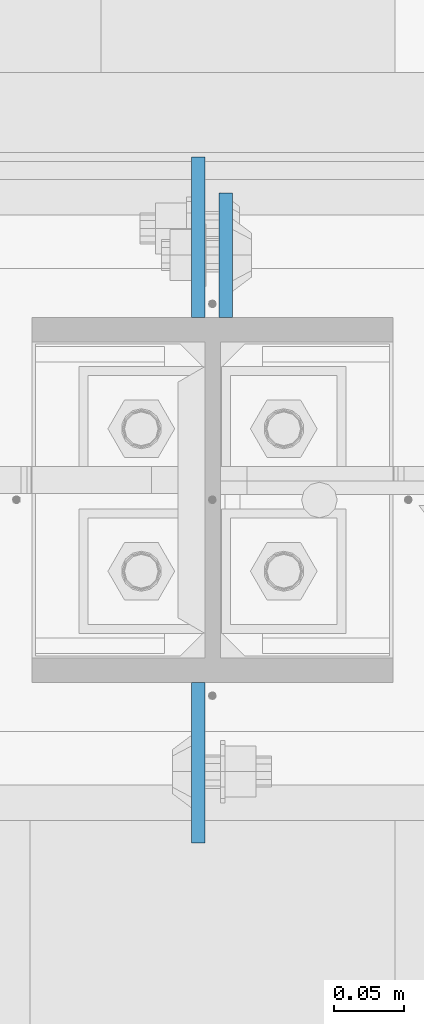
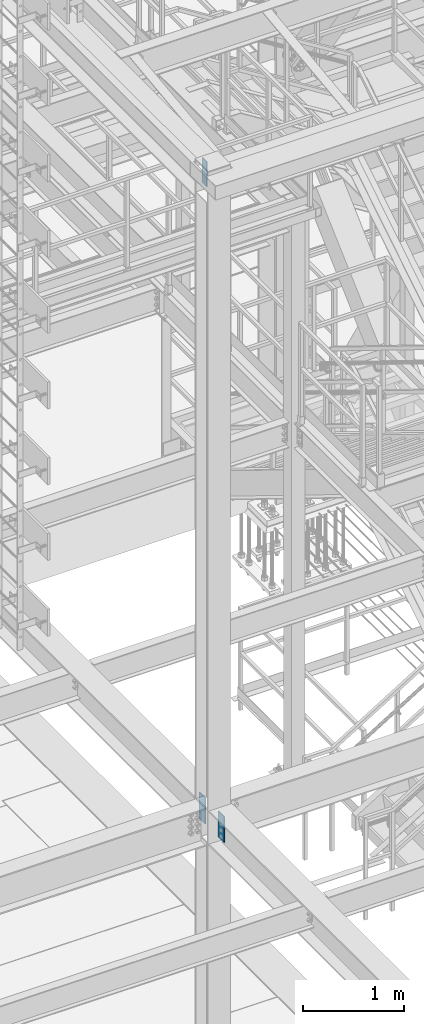
# One storey, part 1466 of 3843: 3 columns, 1 element without a shape of its own.
"""IFC2X3 building model written with IfcOpenShell, lengths in millimetres."""

from ifc_helpers import new_model, si_unit, frame, origin_with_axes, place, context, subcontext, project, spatial, faceted_brep, material, type_object, element, aggregate, save


model = new_model("IFC2X3")

# Units and contexts
model_context = context("Model", 3, precision=1e-05, world=origin_with_axes())
body_context = subcontext(model_context, "Body", "Model", "MODEL_VIEW")
ifc_project = project(units=[si_unit("LENGTHUNIT", "METRE", prefix="MILLI"), si_unit("AREAUNIT", "SQUARE_METRE"), si_unit("VOLUMEUNIT", "CUBIC_METRE"), si_unit("MASSUNIT", "GRAM", prefix="KILO"), si_unit("TIMEUNIT", "SECOND"), si_unit("PLANEANGLEUNIT", "RADIAN"), si_unit("SOLIDANGLEUNIT", "STERADIAN"), si_unit("THERMODYNAMICTEMPERATUREUNIT", "DEGREE_CELSIUS"), si_unit("LUMINOUSINTENSITYUNIT", "LUMEN")], contexts=[model_context])

# Site, building, storey
site_placement = place(None, origin_with_axes())
site = spatial("IfcSite", under=ifc_project, at=site_placement, CompositionType="ELEMENT")
building_placement = place(site_placement, origin_with_axes())
building = spatial("IfcBuilding", under=site, at=building_placement, Name="Undefined", CompositionType="ELEMENT")
storey_placement = place(building_placement, origin_with_axes())
storey = spatial("IfcBuildingStorey", under=building, at=storey_placement, Name="Undefined", CompositionType="ELEMENT", Elevation=0.0)

# Assembly, columns
assembly_placement = place(storey_placement, origin_with_axes())
assembly = element("IfcElementAssembly", 1, at=assembly_placement, inside=storey, Name="COLUMN", AssemblyPlace="NOTDEFINED", PredefinedType="RIGID_FRAME")
ifc_material = material(Name="STEEL/A572-50")
column_type_1 = type_object("IfcColumnType", PredefinedType="NOTDEFINED")
column_1_placement = place(assembly_placement, frame((49006.125, 15173.325, 42125.8999993376), z_axis=(0.0, -1.0, 0.0), x_axis=(0.0, 0.0, 1.0)))
column_1 = element("IfcColumn", 2, at=column_1_placement, type_object=column_type_1, material=ifc_material, Name="PLATE", context=body_context, shape_type="Brep", body=[
    faceted_brep([(0.0, 4.76249999999709, -44.4500000000007), (0.0, 4.76249999999709, 44.4500000000007), (304.799999999996, 4.76249999999709, 44.4500000000007), (304.799999999996, 4.76249999999709, -44.4500000000007), (0.0, -4.76249999999709, 44.4500000000007), (304.799999999996, -4.76249999999709, 44.4500000000007), (0.0, -4.76249999999709, -44.4500000000007), (304.799999999996, -4.76249999999709, -44.4500000000007)], [[[0, 1, 2, 3]], [[1, 4, 5, 2]], [[4, 6, 7, 5]], [[6, 0, 3, 7]], [[5, 7, 3, 2]], [[6, 4, 1, 0]]]),
])
column_type_2 = type_object("IfcColumnType", PredefinedType="NOTDEFINED")
column_2_placement = place(assembly_placement, frame((48986.2814997673, 15186.025, 34442.3999987957), z_axis=(0.0, -1.0, 0.0), x_axis=(0.0, 0.0, 1.0)))
column_2 = element("IfcColumn", 3, at=column_2_placement, type_object=column_type_2, material=ifc_material, Name="PLATE", context=body_context, shape_type="Brep", body=[
    faceted_brep([(0.0, 4.76249999999709, -57.1500000000015), (0.0, 4.76249999999709, 57.1500000000015), (317.5, 4.76249999999709, 57.1499999999996), (317.5, 4.76249999999709, -57.1499999999996), (0.0, -4.76249999999709, 57.1500000000015), (317.5, -4.76249999999709, 57.1499999999996), (0.0, -4.76249999999709, -57.1500000000015), (317.5, -4.76249999999709, -57.1499999999996)], [[[0, 1, 2, 3]], [[1, 4, 5, 2]], [[4, 6, 7, 5]], [[6, 0, 3, 7]], [[5, 7, 3, 2]], [[6, 4, 1, 0]]]),
])
column_3_placement = place(assembly_placement, frame((48986.2814997673, 14811.375, 34442.3999987956), z_axis=(0.0, 1.0, 0.0), x_axis=(0.0, 0.0, 1.0)))
column_3 = element("IfcColumn", 4, at=column_3_placement, type_object=column_type_2, material=ifc_material, Name="PLATE", context=body_context, shape_type="Brep", body=[
    faceted_brep([(0.0, 4.76249999999709, -57.1500000000015), (0.0, 4.76249999999709, 57.1500000000015), (317.5, 4.76249999999709, 57.1499999999996), (317.5, 4.76249999999709, -57.1499999999996), (0.0, -4.76249999999709, 57.1500000000015), (317.5, -4.76249999999709, 57.1499999999996), (0.0, -4.76249999999709, -57.1500000000015), (317.5, -4.76249999999709, -57.1499999999996)], [[[0, 1, 2, 3]], [[1, 4, 5, 2]], [[4, 6, 7, 5]], [[6, 0, 3, 7]], [[5, 7, 3, 2]], [[6, 4, 1, 0]]]),
])
aggregate(assembly, [column_1, column_2, column_3])

save(model, "model.ifc")
